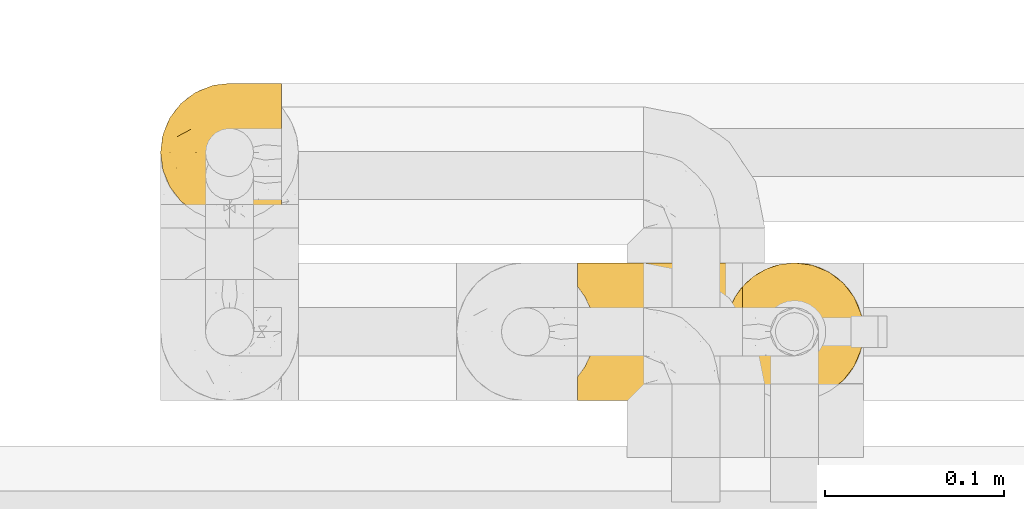
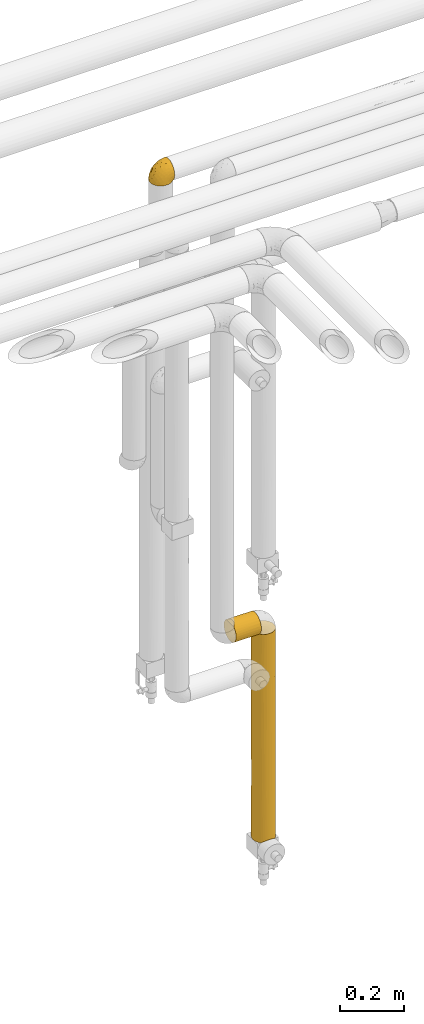
# One storey, part 329 of 827: 3 coverings.
"""IFC2X3 building model written with IfcOpenShell, lengths in millimetres."""

from ifc_helpers import new_model, entity, si_unit, converted_unit, derived_unit, direction, frame, origin, place, context, subcontext, project, spatial, faceted_brep, element, save


model = new_model("IFC2X3")

# Units and contexts
model_context = context("Model", 3, precision=0.01, world=origin(), true_north=direction((6.12303176911189e-17, 1.0)))
body_context = subcontext(model_context, "Body", "Model", "MODEL_VIEW")
ifc_project = project(units=[si_unit("LENGTHUNIT", "METRE", prefix="MILLI"), si_unit("AREAUNIT", "SQUARE_METRE"), si_unit("VOLUMEUNIT", "CUBIC_METRE"), converted_unit("PLANEANGLEUNIT", "DEGREE", entity("IfcRatioMeasure", 0.0174532925199433), si_unit("PLANEANGLEUNIT", "RADIAN"), dimensions=[0, 0, 0, 0, 0, 0, 0]), si_unit("MASSUNIT", "GRAM", prefix="KILO"), derived_unit("MASSDENSITYUNIT", [(si_unit("MASSUNIT", "GRAM", prefix="KILO"), 1), (si_unit("LENGTHUNIT", "METRE"), -3)]), derived_unit("MOMENTOFINERTIAUNIT", [(si_unit("LENGTHUNIT", "METRE"), 4)]), si_unit("TIMEUNIT", "SECOND"), si_unit("FREQUENCYUNIT", "HERTZ"), si_unit("THERMODYNAMICTEMPERATUREUNIT", "DEGREE_CELSIUS"), derived_unit("THERMALTRANSMITTANCEUNIT", [(si_unit("MASSUNIT", "GRAM", prefix="KILO"), 1), (si_unit("THERMODYNAMICTEMPERATUREUNIT", "KELVIN"), -1), (si_unit("TIMEUNIT", "SECOND"), -3)]), derived_unit("VOLUMETRICFLOWRATEUNIT", [(si_unit("LENGTHUNIT", "METRE"), 3), (si_unit("TIMEUNIT", "SECOND"), -1)]), derived_unit("MASSFLOWRATEUNIT", [(si_unit("MASSUNIT", "GRAM", prefix="KILO"), 1), (si_unit("TIMEUNIT", "SECOND"), -1)]), derived_unit("ROTATIONALFREQUENCYUNIT", [(si_unit("TIMEUNIT", "SECOND"), -1)]), si_unit("ELECTRICCURRENTUNIT", "AMPERE"), si_unit("ELECTRICVOLTAGEUNIT", "VOLT"), si_unit("POWERUNIT", "WATT"), si_unit("FORCEUNIT", "NEWTON", prefix="KILO"), si_unit("ILLUMINANCEUNIT", "LUX"), si_unit("LUMINOUSFLUXUNIT", "LUMEN"), si_unit("LUMINOUSINTENSITYUNIT", "CANDELA"), derived_unit("USERDEFINED", [(si_unit("MASSUNIT", "GRAM", prefix="KILO"), -1), (si_unit("LENGTHUNIT", "METRE"), -2), (si_unit("TIMEUNIT", "SECOND"), 3), (si_unit("LUMINOUSFLUXUNIT", "LUMEN"), 1)]), derived_unit("LINEARVELOCITYUNIT", [(si_unit("LENGTHUNIT", "METRE"), 1), (si_unit("TIMEUNIT", "SECOND"), -1)]), si_unit("PRESSUREUNIT", "PASCAL"), derived_unit("USERDEFINED", [(si_unit("LENGTHUNIT", "METRE"), -2), (si_unit("MASSUNIT", "GRAM", prefix="KILO"), 1), (si_unit("TIMEUNIT", "SECOND"), -2)]), derived_unit("LINEARFORCEUNIT", [(si_unit("MASSUNIT", "GRAM", prefix="KILO"), 1), (si_unit("LENGTHUNIT", "METRE"), 1), (si_unit("TIMEUNIT", "SECOND"), -2), (si_unit("LENGTHUNIT", "METRE"), -1)]), derived_unit("PLANARFORCEUNIT", [(si_unit("MASSUNIT", "GRAM", prefix="KILO"), 1), (si_unit("LENGTHUNIT", "METRE"), 1), (si_unit("TIMEUNIT", "SECOND"), -2), (si_unit("LENGTHUNIT", "METRE"), -2)])], contexts=[model_context])

# Site, building, storey
site_placement = place(None, origin())
site = spatial("IfcSite", under=ifc_project, at=site_placement, CompositionType="ELEMENT")
building_placement = place(site_placement, origin())
building = spatial("IfcBuilding", under=site, at=building_placement, CompositionType="ELEMENT")
storey_placement = place(building_placement, frame((0.0, 0.0, 28200.0)))
storey = spatial("IfcBuildingStorey", under=building, at=storey_placement, Name="08", CompositionType="ELEMENT", Elevation=28200.0)

# Coverings
covering_1_placement = place(storey_placement, frame((34717.93, 18294.92, 1190.0)))
element("IfcCovering", 1, at=covering_1_placement, inside=storey, Name=":ADSK_", ObjectType=":ADSK_", PredefinedType="INSULATION", context=body_context, shape_type="Brep", body=[
    faceted_brep([(93.4, 77.51, 31.79), (93.4, 78.4, 40.0), (93.4, 77.09, 49.93), (93.4, 73.25, 59.2), (93.4, 67.15, 67.15), (93.4, 59.2, 73.25), (93.4, 49.93, 77.09), (93.4, 40.0, 78.4), (93.4, 30.06, 77.09), (93.4, 20.8, 73.25), (93.4, 12.84, 67.15), (93.4, 6.74, 59.2), (93.4, 2.9, 49.93), (93.4, 1.6, 40.0), (93.4, 2.48, 31.79), (93.4, 5.09, 23.98), (93.4, 9.31, 16.91), (93.4, 14.94, 10.9), (93.4, 65.05, 10.9), (93.4, 70.68, 16.91), (93.4, 74.9, 23.98), (1.6, 77.51, 48.2), (1.6, 78.4, 40.0), (1.6, 77.09, 30.06), (1.6, 73.25, 20.8), (1.6, 67.15, 12.84), (1.6, 59.2, 6.74), (1.6, 49.93, 2.9), (1.6, 40.0, 1.6), (1.6, 30.06, 2.9), (1.6, 20.8, 6.74), (1.6, 12.84, 12.84), (1.6, 6.74, 20.8), (1.6, 2.9, 30.06), (1.6, 1.6, 40.0), (1.6, 2.48, 48.2), (1.6, 5.09, 56.01), (1.6, 9.31, 63.08), (1.6, 14.94, 69.1), (1.6, 65.05, 69.1), (1.6, 70.68, 63.08), (1.6, 74.9, 56.01), (86.5, 26.63, 4.0), (84.7, 33.21, 2.2), (84.1, 40.0, 1.6), (89.42, 20.48, 6.92), (84.7, 46.78, 2.2), (86.5, 53.36, 4.0), (89.42, 59.51, 6.92), (5.57, 59.51, 73.07), (8.5, 53.36, 76.0), (10.29, 46.78, 77.79), (10.9, 40.0, 78.4), (10.29, 33.21, 77.79), (8.5, 26.63, 76.0), (5.57, 20.48, 73.07)], [[[0, 1, 2, 3, 4, 5, 6, 7, 8, 9, 10, 11, 12, 13, 14, 15, 16, 17, 18, 19, 20]], [[21, 22, 23, 24, 25, 26, 27, 28, 29, 30, 31, 32, 33, 34, 35, 36, 37, 38, 39, 40, 41]], [[34, 33, 14]], [[32, 31, 16]], [[33, 32, 15]], [[14, 13, 34]], [[16, 15, 32]], [[14, 33, 15]], [[31, 17, 16]], [[42, 30, 29]], [[29, 28, 43]], [[44, 43, 28]], [[45, 17, 30]], [[43, 42, 29]], [[45, 30, 42]], [[30, 17, 31]], [[46, 44, 28]], [[46, 28, 27]], [[47, 27, 26]], [[47, 46, 27]], [[18, 48, 26]], [[47, 26, 48]], [[26, 25, 18]], [[19, 25, 24]], [[20, 24, 23]], [[0, 23, 22]], [[19, 24, 20]], [[20, 23, 0]], [[22, 1, 0]], [[25, 19, 18]], [[1, 22, 21]], [[2, 21, 41]], [[3, 41, 40]], [[1, 21, 2]], [[2, 41, 3]], [[40, 4, 3]], [[40, 39, 4]], [[39, 49, 5]], [[50, 51, 6]], [[49, 50, 5]], [[5, 50, 6]], [[7, 6, 51]], [[52, 7, 51]], [[39, 5, 4]], [[53, 54, 8]], [[55, 38, 9]], [[54, 55, 9]], [[52, 53, 7]], [[7, 53, 8]], [[54, 9, 8]], [[38, 10, 9]], [[11, 37, 36]], [[12, 36, 35]], [[13, 35, 34]], [[10, 37, 11]], [[11, 36, 12]], [[35, 13, 12]], [[37, 10, 38]], [[43, 44, 46, 47, 48, 18, 17, 45, 42]], [[38, 55, 54, 53, 52, 51, 50, 49, 39]]]),
])
covering_2_placement = place(storey_placement, frame((34800.43, 18294.92, 399.4)))
element("IfcCovering", 2, at=covering_2_placement, inside=storey, Name=":ADSK_", ObjectType=":ADSK_", PredefinedType="INSULATION", context=body_context, shape_type="Brep", body=[
    faceted_brep([(73.25, 20.8, 801.5), (77.09, 30.06, 801.5), (78.4, 40.0, 801.5), (77.09, 49.93, 801.5), (73.25, 59.2, 801.5), (67.15, 67.15, 801.5), (59.2, 73.25, 801.5), (49.93, 77.09, 801.5), (40.0, 78.4, 801.5), (31.79, 77.51, 801.5), (23.98, 74.9, 801.5), (16.91, 70.68, 801.5), (10.9, 65.05, 801.5), (10.9, 14.94, 801.5), (16.91, 9.31, 801.5), (23.98, 5.09, 801.5), (31.79, 2.48, 801.5), (40.0, 1.6, 801.5), (49.93, 2.9, 801.5), (59.2, 6.74, 801.5), (67.15, 12.84, 801.5), (77.09, 49.93, 1.6), (78.4, 40.0, 1.6), (77.52, 31.83, 1.6), (74.93, 24.05, 1.6), (70.75, 17.0, 1.6), (65.17, 11.0, 1.6), (14.82, 11.0, 1.6), (9.24, 17.0, 1.6), (5.06, 24.05, 1.6), (2.47, 31.83, 1.6), (1.6, 40.0, 1.6), (2.9, 49.93, 1.6), (6.74, 59.2, 1.6), (12.84, 67.15, 1.6), (20.8, 73.25, 1.6), (30.06, 77.09, 1.6), (40.0, 78.4, 1.6), (49.93, 77.09, 1.6), (59.2, 73.25, 1.6), (67.15, 67.15, 1.6), (73.25, 59.2, 1.6), (1.6, 40.0, 359.45), (11.62, 14.12, 200.39), (17.38, 8.96, 237.59), (6.96, 20.41, 200.14), (21.25, 6.48, 604.58), (15.59, 10.35, 517.84), (31.13, 2.63, 505.4), (23.22, 5.45, 398.49), (4.0, 26.63, 794.6), (2.2, 33.21, 792.8), (2.98, 29.79, 485.61), (1.6, 40.0, 575.82), (5.59, 22.94, 507.19), (3.56, 27.87, 232.57), (6.92, 20.48, 797.52), (8.86, 17.52, 615.32), (40.0, 1.6, 227.37), (33.17, 2.21, 10.38), (40.0, 1.6, 11.0), (20.38, 6.98, 5.61), (26.56, 4.02, 8.57), (23.32, 5.4, 187.77), (29.75, 2.99, 243.58), (40.0, 1.6, 443.74), (8.95, 17.4, 406.53), (1.6, 40.0, 792.2), (46.82, 2.21, 10.38), (53.43, 4.02, 8.57), (50.26, 2.99, 318.6), (54.38, 4.39, 562.68), (46.52, 2.15, 586.86), (64.31, 10.27, 614.59), (62.71, 9.03, 405.54), (68.49, 14.26, 475.47), (57.16, 5.64, 302.73), (59.61, 6.98, 5.61), (62.59, 8.94, 192.41), (76.5, 28.07, 529.41), (76.43, 27.87, 250.93), (78.4, 40.0, 434.34), (68.12, 13.85, 240.34), (73.03, 20.41, 392.89), (78.4, 40.0, 217.97), (73.03, 20.41, 179.35), (72.13, 18.98, 598.91), (78.4, 40.0, 585.12), (78.4, 40.0, 368.75), (75.47, 54.69, 242.08), (63.37, 70.46, 242.08), (53.84, 75.81, 184.94), (77.73, 47.11, 476.94), (77.78, 46.85, 241.01), (70.46, 63.37, 627.75), (75.47, 54.69, 522.83), (70.46, 63.37, 175.34), (70.46, 63.37, 401.55), (54.69, 75.47, 401.55), (63.37, 70.46, 522.83), (46.78, 77.79, 239.09), (53.45, 75.96, 613.87), (40.0, 78.4, 201.57), (40.0, 78.4, 368.75), (40.0, 78.4, 401.55), (40.0, 78.4, 585.12), (47.49, 77.66, 493.33), (18.9, 72.08, 203.77), (27.97, 76.47, 273.09), (27.82, 76.41, 551.67), (13.75, 68.03, 563.11), (8.86, 62.48, 610.84), (5.6, 57.07, 500.74), (8.95, 62.6, 398.08), (14.17, 68.41, 327.26), (20.33, 72.98, 410.23), (20.33, 72.98, 623.93), (2.2, 46.78, 792.8), (2.98, 50.2, 485.61), (4.0, 53.36, 794.6), (2.14, 46.45, 214.56), (6.92, 59.51, 797.52), (4.35, 54.28, 241.46), (10.17, 64.19, 187.37)], [[[0, 1, 2, 3, 4, 5, 6, 7, 8, 9, 10, 11, 12, 13, 14, 15, 16, 17, 18, 19, 20]], [[21, 22, 23, 24, 25, 26, 27, 28, 29, 30, 31, 32, 33, 34, 35, 36, 37, 38, 39, 40, 41]], [[42, 31, 30]], [[43, 27, 44]], [[28, 45, 29]], [[46, 14, 47]], [[48, 46, 49]], [[50, 51, 52]], [[51, 53, 52]], [[45, 54, 55]], [[55, 42, 30]], [[52, 54, 50]], [[13, 56, 57]], [[17, 16, 48]], [[58, 59, 60]], [[49, 46, 47]], [[61, 62, 63]], [[59, 58, 64]], [[62, 59, 64]], [[48, 64, 65]], [[44, 63, 49]], [[29, 55, 30]], [[54, 66, 57]], [[63, 62, 64]], [[13, 47, 14]], [[61, 44, 27]], [[64, 48, 49]], [[49, 47, 44]], [[42, 55, 52]], [[55, 29, 45]], [[46, 48, 15]], [[43, 47, 66]], [[56, 50, 54]], [[57, 47, 13]], [[47, 57, 66]], [[66, 45, 43]], [[17, 48, 65]], [[15, 48, 16]], [[54, 57, 56]], [[55, 54, 52]], [[43, 45, 28]], [[45, 66, 54]], [[27, 43, 28]], [[43, 44, 47]], [[49, 63, 64]], [[61, 63, 44]], [[53, 51, 67]], [[53, 42, 52]], [[58, 65, 64]], [[14, 46, 15]], [[60, 68, 58]], [[68, 69, 70]], [[71, 72, 70]], [[73, 74, 75]], [[76, 69, 77]], [[77, 26, 78]], [[68, 70, 58]], [[0, 79, 1]], [[79, 80, 81]], [[82, 26, 25]], [[17, 65, 72]], [[83, 80, 79]], [[71, 70, 76]], [[23, 84, 80]], [[85, 25, 24]], [[82, 78, 26]], [[85, 80, 83]], [[85, 82, 25]], [[75, 82, 83]], [[2, 1, 79]], [[76, 77, 78]], [[75, 74, 82]], [[23, 80, 24]], [[86, 79, 0]], [[72, 71, 18]], [[79, 81, 87, 2]], [[74, 78, 82]], [[76, 78, 74]], [[20, 75, 86]], [[74, 73, 71]], [[69, 76, 70]], [[74, 71, 76]], [[19, 18, 71]], [[80, 85, 24]], [[82, 85, 83]], [[86, 75, 83]], [[73, 75, 20]], [[20, 19, 73]], [[71, 73, 19]], [[79, 86, 83]], [[20, 86, 0]], [[17, 72, 18]], [[70, 72, 65]], [[70, 65, 58]], [[84, 23, 22]], [[80, 84, 88, 81]], [[21, 41, 89]], [[90, 39, 91]], [[92, 88, 93]], [[94, 95, 89, 96, 97]], [[93, 22, 21]], [[40, 96, 41]], [[92, 87, 81, 88]], [[94, 5, 4]], [[4, 3, 95]], [[98, 99, 90]], [[97, 96, 90, 99, 94]], [[91, 38, 100]], [[101, 99, 98]], [[100, 37, 102, 103, 104]], [[94, 99, 5]], [[39, 90, 40]], [[3, 87, 92]], [[6, 5, 99]], [[8, 7, 105]], [[98, 106, 101]], [[92, 93, 89]], [[104, 106, 100]], [[89, 41, 96]], [[7, 101, 106]], [[3, 2, 87]], [[89, 95, 92]], [[3, 92, 95]], [[93, 88, 84, 22]], [[21, 89, 93]], [[7, 106, 105]], [[104, 105, 106]], [[98, 91, 100]], [[98, 100, 106]], [[37, 100, 38]], [[7, 6, 101]], [[99, 101, 6]], [[90, 91, 98]], [[39, 38, 91]], [[95, 94, 4]], [[90, 96, 40]], [[107, 108, 35]], [[9, 105, 109]], [[9, 109, 10]], [[110, 111, 12]], [[112, 111, 113]], [[113, 110, 114]], [[115, 109, 108]], [[108, 37, 36]], [[34, 114, 107]], [[115, 116, 109]], [[116, 11, 10]], [[108, 109, 103]], [[111, 110, 113]], [[35, 108, 36]], [[110, 12, 11]], [[116, 110, 11]], [[53, 117, 118]], [[108, 103, 102, 37]], [[117, 119, 118]], [[42, 120, 31]], [[12, 111, 121]], [[117, 53, 67]], [[112, 119, 121]], [[122, 120, 118]], [[123, 113, 114]], [[120, 122, 32]], [[112, 122, 118]], [[114, 110, 115]], [[112, 121, 111]], [[113, 123, 122]], [[119, 112, 118]], [[113, 122, 112]], [[33, 32, 122]], [[109, 116, 10]], [[110, 116, 115]], [[107, 114, 115]], [[123, 114, 34]], [[34, 33, 123]], [[122, 123, 33]], [[108, 107, 115]], [[34, 107, 35]], [[31, 120, 32]], [[118, 120, 42]], [[118, 42, 53]], [[105, 9, 8]], [[109, 105, 104, 103]], [[117, 67, 51, 50, 56, 13, 12, 121, 119]], [[77, 69, 68, 60, 59, 62, 61, 27, 26]]]),
])
covering_3_placement = place(storey_placement, frame((34485.34, 18394.86, 2969.47)))
element("IfcCovering", 3, at=covering_3_placement, inside=storey, Name=":ADSK_", ObjectType=":ADSK_", PredefinedType="INSULATION", context=body_context, shape_type="Brep", body=[
    faceted_brep([(69.15, 74.68, 47.38), (69.15, 70.1, 54.67), (69.15, 64.01, 60.76), (69.15, 56.72, 65.34), (69.15, 48.6, 68.18), (69.15, 40.05, 69.15), (69.15, 31.49, 68.18), (69.15, 23.36, 65.33), (69.15, 16.07, 60.75), (69.15, 9.98, 54.66), (69.15, 5.4, 47.37), (69.15, 2.56, 39.25), (69.15, 1.6, 30.7), (69.15, 2.46, 22.59), (69.15, 5.01, 14.86), (69.15, 9.13, 7.84), (69.15, 14.62, 1.85), (69.15, 16.82, 1.85), (69.15, 18.56, 1.85), (69.15, 20.52, 1.85), (69.15, 22.49, 1.85), (69.15, 24.46, 1.85), (69.15, 26.42, 1.85), (69.15, 28.39, 1.85), (69.15, 30.36, 1.85), (69.15, 32.55, 1.85), (69.15, 34.75, 1.85), (69.15, 36.94, 1.85), (69.15, 39.13, 1.85), (69.15, 41.33, 1.85), (69.15, 43.52, 1.85), (69.15, 45.72, 1.85), (69.15, 47.91, 1.85), (69.15, 50.11, 1.85), (69.15, 52.3, 1.85), (69.15, 54.49, 1.85), (69.15, 56.69, 1.85), (69.15, 58.88, 1.85), (69.15, 61.08, 1.85), (69.15, 63.27, 1.85), (69.15, 65.47, 1.85), (69.15, 70.97, 7.85), (69.15, 75.09, 14.88), (69.15, 77.64, 22.61), (69.15, 78.5, 30.7), (69.15, 77.53, 39.26), (68.89, 14.62, 1.6), (62.89, 9.12, 1.6), (55.87, 5.0, 1.6), (48.14, 2.46, 1.6), (40.05, 1.6, 1.6), (30.09, 2.91, 1.6), (20.82, 6.75, 1.6), (12.86, 12.86, 1.6), (6.75, 20.82, 1.6), (2.91, 30.09, 1.6), (1.6, 40.05, 1.6), (2.91, 50.0, 1.6), (6.75, 59.27, 1.6), (12.86, 67.23, 1.6), (20.82, 73.34, 1.6), (30.09, 77.19, 1.6), (40.05, 78.5, 1.6), (48.14, 77.63, 1.6), (55.87, 75.09, 1.6), (62.89, 70.97, 1.6), (68.89, 65.47, 1.6), (68.89, 63.27, 1.6), (68.89, 62.29, 1.6), (68.89, 60.7, 1.6), (68.89, 59.11, 1.6), (68.89, 57.52, 1.6), (68.89, 55.93, 1.6), (68.89, 54.34, 1.6), (68.89, 52.76, 1.6), (68.89, 51.17, 1.6), (68.89, 49.58, 1.6), (68.89, 47.99, 1.6), (68.89, 46.4, 1.6), (68.89, 44.81, 1.6), (68.89, 43.22, 1.6), (68.89, 41.63, 1.6), (68.89, 40.05, 1.6), (68.89, 38.46, 1.6), (68.89, 36.87, 1.6), (68.89, 35.28, 1.6), (68.89, 33.69, 1.6), (68.89, 32.1, 1.6), (68.89, 30.51, 1.6), (68.89, 28.92, 1.6), (68.89, 27.33, 1.6), (68.89, 25.37, 1.6), (68.89, 23.4, 1.6), (68.89, 21.21, 1.6), (68.89, 19.01, 1.6), (68.89, 16.82, 1.6), (68.97, 42.32, 1.78), (68.96, 44.02, 1.77), (68.97, 47.13, 1.78), (68.97, 48.74, 1.77), (68.98, 23.57, 1.79), (68.97, 25.13, 1.78), (68.96, 61.34, 1.76), (68.96, 22.02, 1.77), (68.96, 29.72, 1.77), (68.96, 56.73, 1.76), (68.96, 55.14, 1.77), (68.96, 37.66, 1.77), (69.0, 64.12, 1.8), (68.96, 28.13, 1.76), (68.96, 26.62, 1.77), (68.97, 31.46, 1.78), (68.96, 16.16, 1.77), (68.96, 39.16, 1.77), (68.96, 50.37, 1.76), (68.97, 17.69, 1.77), (68.97, 19.17, 1.78), (68.97, 62.78, 1.77), (68.96, 58.35, 1.77), (68.96, 45.53, 1.77), (68.97, 59.91, 1.78), (68.97, 65.47, 1.77), (69.02, 65.47, 1.8), (69.08, 65.47, 1.82), (68.97, 14.62, 1.77), (68.94, 14.62, 1.72), (68.92, 14.62, 1.66), (68.96, 20.59, 1.76), (68.96, 32.99, 1.77), (68.95, 34.48, 1.76), (68.96, 51.91, 1.77), (68.92, 65.47, 1.66), (68.94, 65.47, 1.72), (68.98, 53.48, 1.78), (69.08, 14.62, 1.82), (69.02, 14.62, 1.8), (68.96, 40.77, 1.77), (68.97, 35.97, 1.78), (61.33, 7.84, 3.72), (53.1, 3.53, 7.41), (63.33, 8.32, 6.13), (55.53, 2.19, 19.34), (63.33, 3.53, 17.64), (54.6, 1.6, 26.8), (41.99, 1.6, 8.87), (57.07, 4.57, 9.2), (57.95, 3.96, 12.79), (51.56, 2.28, 14.62), (41.58, 1.6, 7.34), (61.7, 7.69, 5.33), (65.0, 8.32, 7.7), (67.02, 7.84, 9.41), (61.87, 1.6, 28.75), (49.27, 1.6, 21.47), (43.94, 1.6, 16.15), (61.21, 4.34, 14.14), (63.4, 1.6, 29.16), (33.11, 29.63, 57.02), (52.82, 27.34, 64.92), (43.3, 40.05, 64.0), (33.73, 2.39, 11.92), (36.52, 2.43, 19.16), (24.87, 9.07, 28.65), (14.17, 16.64, 24.62), (18.43, 9.54, 15.19), (28.67, 4.52, 18.36), (26.0, 4.52, 9.2), (49.25, 7.49, 46.98), (59.72, 7.49, 50.24), (55.1, 12.85, 56.1), (44.72, 2.35, 28.97), (34.15, 22.66, 54.46), (5.25, 32.9, 21.34), (6.75, 25.33, 18.4), (55.54, 40.05, 66.44), (10.47, 16.64, 12.07), (25.49, 19.99, 45.49), (35.53, 16.37, 50.57), (48.22, 3.26, 36.04), (58.71, 3.75, 42.07), (57.42, 19.58, 62.12), (34.84, 7.5, 37.37), (36.87, 4.04, 29.39), (45.01, 13.94, 53.59), (44.4, 19.58, 58.06), (23.96, 28.21, 49.27), (11.2, 24.75, 29.63), (10.56, 31.42, 33.21), (16.81, 26.2, 40.1), (17.38, 33.36, 44.08), (21.38, 40.05, 49.36), (32.34, 40.05, 56.68), (4.3, 40.05, 15.2), (20.65, 16.14, 35.57), (29.66, 12.85, 41.7), (39.6, 10.47, 46.4), (42.55, 6.49, 41.41), (6.74, 40.05, 27.45), (14.06, 40.05, 38.4), (26.84, 75.57, 12.99), (5.28, 47.37, 21.33), (18.52, 52.91, 42.89), (33.13, 50.46, 57.04), (55.1, 67.23, 56.11), (57.43, 60.5, 62.13), (20.72, 70.55, 21.89), (11.46, 63.45, 16.62), (17.69, 62.61, 32.9), (49.26, 72.6, 46.99), (59.73, 72.6, 50.25), (58.71, 76.34, 42.08), (29.72, 59.34, 49.91), (35.35, 77.76, 15.6), (43.94, 78.5, 16.15), (41.99, 78.5, 8.87), (63.4, 78.5, 29.16), (4.93, 53.16, 13.16), (17.46, 70.55, 10.83), (10.94, 48.88, 33.8), (8.92, 54.76, 25.02), (52.83, 52.74, 64.92), (29.34, 71.93, 32.83), (30.26, 75.79, 20.56), (44.4, 60.5, 58.07), (39.06, 77.86, 21.46), (43.06, 77.64, 28.1), (54.6, 78.5, 26.8), (49.27, 78.5, 21.47), (42.69, 67.23, 51.29), (48.2, 76.82, 36.04), (61.87, 78.5, 28.75), (33.44, 77.8, 8.45), (29.67, 67.23, 41.73), (38.5, 73.2, 39.27), (23.35, 67.66, 33.56), (34.97, 75.99, 27.29), (53.1, 76.57, 7.41), (59.68, 73.21, 3.51), (62.19, 71.93, 4.68), (64.11, 71.07, 5.52), (57.97, 75.09, 8.75), (57.95, 76.13, 12.79), (63.33, 76.57, 17.65), (51.77, 77.69, 13.9), (67.02, 72.26, 9.42), (64.98, 71.77, 7.68), (55.53, 77.9, 19.33), (61.22, 75.75, 14.13)], [[[0, 1, 2, 3, 4, 5, 6, 7, 8, 9, 10, 11, 12, 13, 14, 15, 16, 17, 18, 19, 20, 21, 22, 23, 24, 25, 26, 27, 28, 29, 30, 31, 32, 33, 34, 35, 36, 37, 38, 39, 40, 41, 42, 43, 44, 45]], [[46, 47, 48, 49, 50, 51, 52, 53, 54, 55, 56, 57, 58, 59, 60, 61, 62, 63, 64, 65, 66, 67, 68, 69, 70, 71, 72, 73, 74, 75, 76, 77, 78, 79, 80, 81, 82, 83, 84, 85, 86, 87, 88, 89, 90, 91, 92, 93, 94, 95]], [[96, 97, 30]], [[98, 77, 99]], [[100, 101, 21]], [[69, 68, 102]], [[20, 19, 103]], [[24, 23, 104]], [[20, 103, 100]], [[72, 105, 106]], [[84, 83, 107]], [[89, 88, 104]], [[108, 67, 66]], [[109, 110, 90]], [[111, 25, 24]], [[112, 17, 16]], [[82, 113, 83]], [[109, 23, 22]], [[114, 76, 75]], [[105, 36, 106]], [[104, 111, 24]], [[18, 115, 116]], [[97, 96, 80]], [[67, 108, 117]], [[105, 71, 118]], [[31, 97, 119]], [[102, 120, 69]], [[108, 121, 122, 123, 40]], [[112, 95, 115]], [[17, 115, 18]], [[94, 116, 115]], [[117, 68, 67]], [[38, 117, 39]], [[112, 124, 125, 126, 46]], [[17, 112, 115]], [[70, 120, 118]], [[39, 117, 108]], [[120, 38, 37]], [[120, 37, 118]], [[120, 70, 69]], [[116, 94, 127]], [[128, 86, 129]], [[117, 38, 102]], [[74, 130, 75]], [[99, 33, 32]], [[115, 95, 94]], [[39, 108, 40]], [[108, 66, 131, 132, 121]], [[105, 72, 71]], [[118, 37, 36]], [[71, 70, 118]], [[35, 106, 36]], [[36, 105, 118]], [[35, 133, 106]], [[74, 73, 133]], [[106, 133, 73]], [[99, 114, 33]], [[133, 35, 34]], [[73, 72, 106]], [[95, 112, 46]], [[112, 16, 134, 135, 124]], [[130, 114, 75]], [[99, 76, 114]], [[114, 130, 33]], [[34, 33, 130]], [[78, 77, 98]], [[98, 119, 78]], [[130, 133, 34]], [[133, 130, 74]], [[79, 97, 80]], [[98, 99, 32]], [[98, 32, 31]], [[77, 76, 99]], [[97, 79, 119]], [[136, 96, 29]], [[30, 97, 31]], [[136, 29, 28]], [[81, 80, 96]], [[29, 96, 30]], [[31, 119, 98]], [[119, 79, 78]], [[96, 136, 81]], [[82, 81, 136]], [[113, 107, 83]], [[84, 107, 137]], [[107, 27, 137]], [[113, 28, 107]], [[27, 107, 28]], [[85, 84, 137]], [[137, 27, 26]], [[113, 136, 28]], [[136, 113, 82]], [[109, 89, 104]], [[86, 85, 129]], [[89, 109, 90]], [[111, 87, 128]], [[26, 129, 137]], [[88, 111, 104]], [[25, 111, 128]], [[22, 110, 109]], [[23, 109, 104]], [[110, 91, 90]], [[100, 92, 101]], [[110, 22, 101]], [[91, 110, 101]], [[116, 19, 18]], [[111, 88, 87]], [[127, 103, 19]], [[25, 128, 26]], [[86, 128, 87]], [[128, 129, 26]], [[137, 129, 85]], [[120, 102, 38]], [[117, 102, 68]], [[91, 101, 92]], [[21, 101, 22]], [[93, 92, 103]], [[100, 21, 20]], [[100, 103, 92]], [[127, 93, 103]], [[93, 127, 94]], [[116, 127, 19]], [[126, 138, 47]], [[48, 138, 139]], [[140, 125, 124]], [[141, 142, 143]], [[144, 49, 139]], [[145, 140, 146]], [[48, 139, 49]], [[139, 145, 147]], [[49, 144, 148, 50]], [[126, 125, 149]], [[14, 13, 142]], [[150, 146, 140]], [[149, 140, 145]], [[151, 150, 135]], [[151, 14, 142]], [[16, 15, 134]], [[13, 152, 142]], [[124, 150, 140]], [[141, 143, 153]], [[14, 151, 15]], [[15, 151, 134]], [[47, 46, 126]], [[139, 154, 144]], [[138, 48, 47]], [[125, 140, 149]], [[135, 134, 151]], [[146, 155, 141]], [[145, 146, 147]], [[149, 139, 138]], [[147, 153, 154]], [[147, 146, 141]], [[139, 147, 154]], [[139, 149, 145]], [[149, 138, 126]], [[147, 141, 153]], [[146, 150, 155]], [[151, 155, 150]], [[142, 141, 155]], [[13, 12, 156, 152]], [[152, 143, 142]], [[151, 142, 155]], [[150, 124, 135]], [[157, 158, 159]], [[160, 154, 161]], [[162, 163, 164]], [[165, 166, 160]], [[167, 168, 169]], [[153, 170, 161]], [[156, 12, 11]], [[158, 157, 171]], [[172, 55, 173]], [[158, 6, 174]], [[175, 54, 53]], [[52, 166, 164]], [[52, 164, 53]], [[54, 175, 173]], [[166, 52, 51]], [[176, 177, 171]], [[178, 143, 179]], [[156, 11, 179]], [[8, 7, 180]], [[169, 9, 8]], [[179, 143, 152, 156]], [[179, 11, 10]], [[168, 179, 10]], [[181, 162, 182]], [[179, 167, 178]], [[183, 184, 177]], [[183, 169, 184]], [[176, 171, 185]], [[172, 186, 187]], [[158, 7, 6]], [[159, 158, 174]], [[184, 180, 158]], [[54, 173, 55]], [[180, 169, 8]], [[188, 189, 187]], [[9, 168, 10]], [[186, 188, 187]], [[190, 157, 159, 191]], [[55, 172, 192]], [[176, 193, 194]], [[161, 170, 182]], [[162, 164, 165]], [[175, 164, 163]], [[51, 50, 148]], [[167, 195, 196]], [[178, 182, 170]], [[6, 5, 174]], [[158, 180, 7]], [[169, 180, 184]], [[169, 168, 9]], [[179, 168, 167]], [[182, 162, 165]], [[162, 194, 193]], [[161, 165, 160]], [[195, 181, 196]], [[192, 172, 197]], [[192, 56, 55]], [[189, 190, 198]], [[198, 197, 187]], [[172, 187, 197]], [[185, 189, 188]], [[198, 187, 189]], [[186, 172, 173]], [[173, 163, 186]], [[193, 186, 163]], [[176, 185, 188]], [[185, 157, 190]], [[188, 186, 193]], [[177, 176, 194]], [[188, 193, 176]], [[162, 193, 163]], [[195, 177, 194]], [[171, 177, 184]], [[181, 195, 194]], [[183, 167, 169]], [[162, 181, 194]], [[196, 182, 178]], [[158, 171, 184]], [[171, 157, 185]], [[177, 195, 183]], [[167, 183, 195]], [[182, 196, 181]], [[178, 170, 143]], [[178, 167, 196]], [[164, 175, 53]], [[173, 175, 163]], [[160, 51, 148]], [[164, 166, 165]], [[51, 160, 166]], [[160, 148, 144, 154]], [[153, 161, 154]], [[182, 165, 161]], [[190, 189, 185]], [[143, 170, 153]], [[60, 199, 61]], [[197, 200, 192]], [[201, 190, 202]], [[200, 57, 192]], [[203, 204, 2]], [[205, 206, 207]], [[208, 209, 210]], [[211, 207, 201]], [[212, 213, 214]], [[45, 215, 210]], [[216, 206, 58]], [[45, 44, 215]], [[59, 217, 60]], [[60, 217, 199]], [[0, 45, 210]], [[218, 201, 219]], [[202, 159, 220]], [[205, 221, 222]], [[223, 204, 203]], [[1, 203, 2]], [[57, 200, 216]], [[220, 3, 204]], [[220, 174, 4]], [[1, 0, 209]], [[212, 224, 213]], [[225, 226, 227]], [[228, 223, 203]], [[208, 210, 229]], [[210, 226, 229]], [[3, 220, 4]], [[58, 206, 59]], [[209, 203, 1]], [[202, 220, 223]], [[228, 203, 208]], [[202, 211, 201]], [[3, 2, 204]], [[202, 190, 191, 159]], [[210, 215, 230, 226]], [[199, 212, 231]], [[232, 233, 221]], [[233, 208, 229]], [[207, 206, 219]], [[217, 206, 205]], [[227, 224, 225]], [[233, 232, 228]], [[201, 207, 219]], [[234, 232, 221]], [[218, 219, 200]], [[202, 223, 211]], [[174, 220, 159]], [[174, 5, 4]], [[61, 231, 62]], [[220, 204, 223]], [[210, 209, 0]], [[203, 209, 208]], [[225, 233, 229]], [[224, 227, 213]], [[221, 233, 235]], [[57, 56, 192]], [[198, 218, 197]], [[200, 219, 216]], [[201, 198, 190]], [[197, 218, 200]], [[198, 201, 218]], [[206, 216, 219]], [[58, 57, 216]], [[231, 212, 214]], [[222, 212, 199]], [[228, 211, 223]], [[207, 211, 232]], [[62, 231, 214]], [[199, 231, 61]], [[233, 228, 208]], [[211, 228, 232]], [[222, 221, 235]], [[234, 205, 207]], [[206, 217, 59]], [[199, 217, 205]], [[205, 222, 199]], [[224, 222, 235]], [[222, 224, 212]], [[224, 235, 225]], [[233, 225, 235]], [[226, 225, 229]], [[205, 234, 221]], [[207, 232, 234]], [[63, 214, 236]], [[214, 213, 236]], [[214, 63, 62]], [[237, 236, 238]], [[238, 132, 131]], [[236, 237, 64]], [[239, 240, 241]], [[63, 236, 64]], [[131, 66, 65]], [[237, 131, 65]], [[242, 230, 43]], [[237, 65, 64]], [[239, 121, 132]], [[42, 242, 43]], [[241, 240, 243]], [[41, 123, 244]], [[43, 230, 215, 44]], [[244, 122, 245]], [[227, 246, 243]], [[245, 241, 247]], [[121, 239, 245]], [[41, 40, 123]], [[132, 238, 239]], [[244, 42, 41]], [[131, 237, 238]], [[240, 239, 238]], [[245, 239, 241]], [[247, 241, 246]], [[247, 244, 245]], [[238, 236, 240]], [[243, 236, 213]], [[236, 243, 240]], [[246, 241, 243]], [[243, 213, 227]], [[226, 242, 246]], [[227, 226, 246]], [[246, 242, 247]], [[244, 247, 242]], [[242, 226, 230]], [[42, 244, 242]], [[122, 244, 123]], [[122, 121, 245]]]),
])

save(model, "model.ifc")
